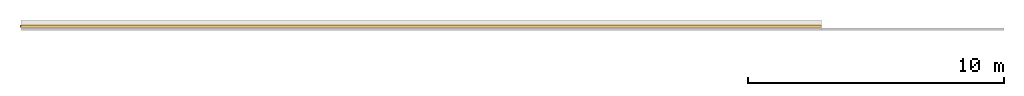
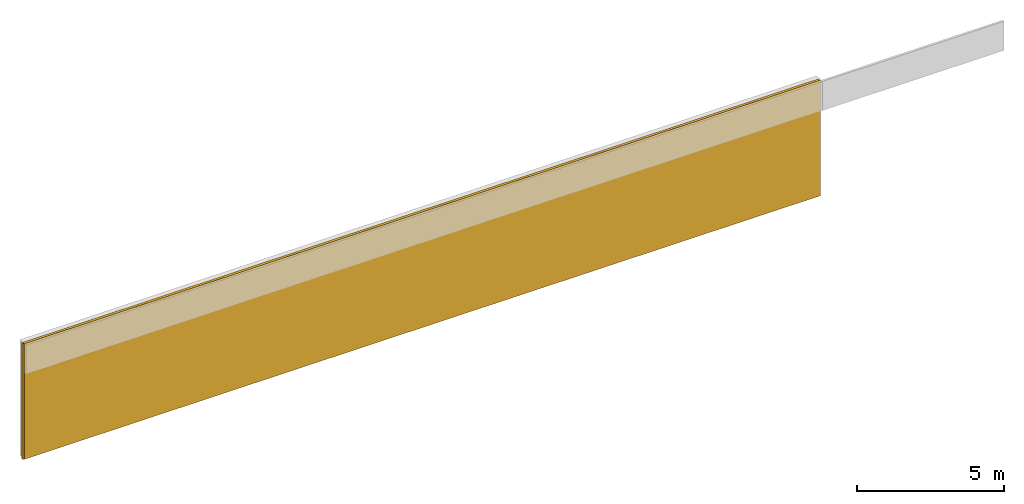
# Not in any storey, part 2 of 2: 2 coverings.
"""IFC4X3_ADD2 model written with IfcOpenShell, lengths in millimetres."""

from ifc_helpers import new_model, entity, si_unit, converted_unit, frame, origin_with_axes, origin_2d_with_axis, place, context, subcontext, project, indexed_curve, outline, extrude, material, layer, layer_set, layer_usage, type_object, element, save


model = new_model("IFC4X3_ADD2")

# Units and contexts
model_context = context("Model", 3, precision=1e-05, world=origin_with_axes())
plan_context = context("Plan", 2, precision=1e-05, world=origin_2d_with_axis())
body_context = subcontext(model_context, "Body", "Model", "MODEL_VIEW")
ifc_project = project(units=[converted_unit("PLANEANGLEUNIT", "degree", entity("IfcReal", 0.0174532925199433), si_unit("PLANEANGLEUNIT", "RADIAN"), dimensions=[0, 0, 0, 0, 0, 0, 0]), si_unit("AREAUNIT", "SQUARE_METRE", prefix="MILLI"), si_unit("VOLUMEUNIT", "CUBIC_METRE", prefix="MILLI"), si_unit("LENGTHUNIT", "METRE", prefix="MILLI")], contexts=[model_context, plan_context])

# Coverings
ifc_material = material(Name="Spray Foam", Category="07215 - on Insulation")
ifc_layer = layer(ifc_material, 100.0, Name="Spray Foam", Category="Insulation")
ifc_layer_set = layer_set([ifc_layer])
ifc_layer_usage_1 = layer_usage(ifc_layer_set, "AXIS2", "POSITIVE", 0.0)
covering_type = type_object("IfcCoveringType", PredefinedType="INSULATION", material=ifc_layer_set)
covering_1_placement = place(None, frame((34477.9205322266, -2897.51672744751, 0.0), z_axis=(0.0, 0.0, 1.0), x_axis=(-0.999999999999803, 6.27832946520233e-07, 0.0)))
element("IfcCovering", 1, at=covering_1_placement, type_object=covering_type, material=ifc_layer_usage_1, Name="Covering", context=body_context, shape_type="SweptSolid", body=[
    extrude(outline(indexed_curve([(0.0, 0.0), (0.0, 100.0), (31278.9270413143, 100.0), (31278.9270413143, 0.0), (0.0, 0.0)], self_intersect=False)), origin_with_axes(), (0.0, 0.0, 1.0), 4800.00019073486),
])
ifc_layer_usage_2 = layer_usage(ifc_layer_set, "AXIS2", "POSITIVE", 0.0)
covering_2_placement = place(None, frame((34477.9205322266, -2897.51648902893, 0.0), z_axis=(0.0, 0.0, 1.0), x_axis=(-0.999999999999803, 6.27832946520233e-07, 0.0)))
element("IfcCovering", 2, at=covering_2_placement, type_object=covering_type, material=ifc_layer_usage_2, Name="Covering", context=body_context, shape_type="SweptSolid", body=[
    extrude(outline(indexed_curve([(0.0, 0.0), (0.0, 100.0), (31320.537578706, 100.0), (31320.537578706, 0.0), (0.0, 0.0)], self_intersect=False)), origin_with_axes(), (0.0, 0.0, 1.0), 4800.00019073486),
])

save(model, "model.ifc")
